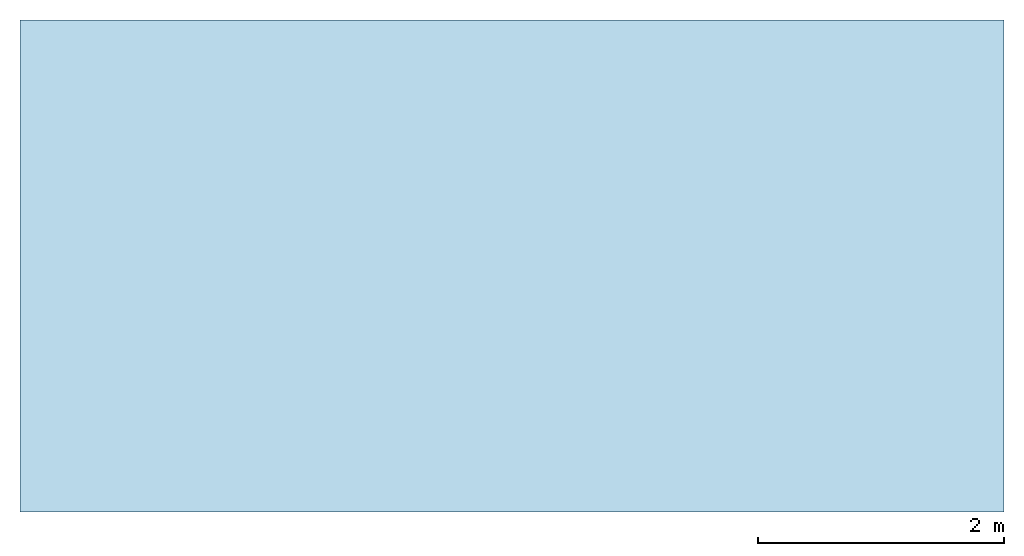
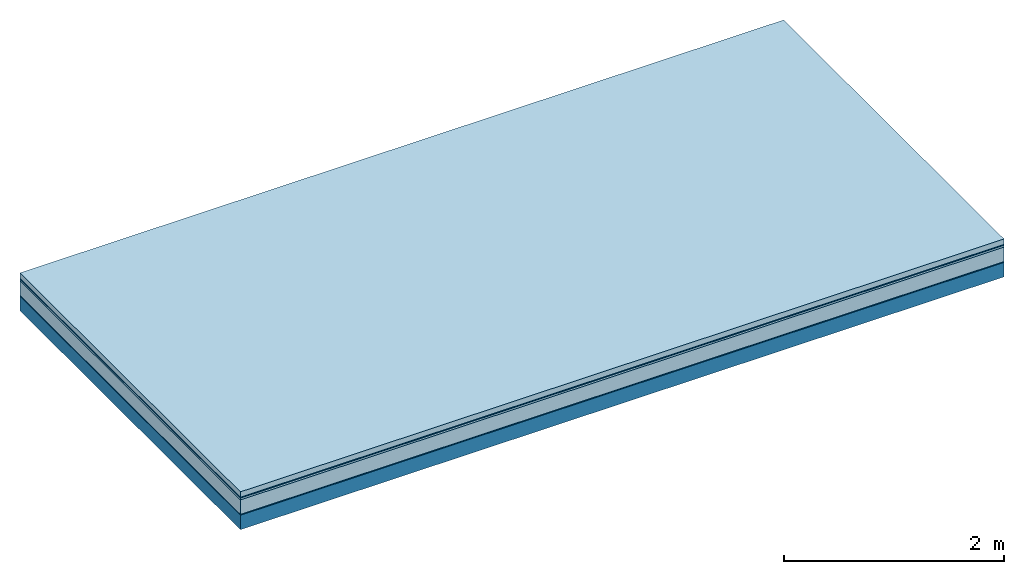
# One storey: 5 plates, 1 member, 1 element without a shape of its own.
"""IFC4 building model written with IfcOpenShell, lengths in metres."""

from ifc_helpers import new_model, si_unit, derived_unit, direction, frame, frame_2d, origin, origin_with_axes, place, context, project, spatial, rectangle, extrude, material, layer, layer_set, type_object, element, aggregate, save


model = new_model("IFC4")

# Units and contexts
plan_context = context("Plan", 3, precision=1e-05, world=origin(), true_north=direction((0.0, 1.0)))
model_context = context("Model", 3, precision=1e-05, world=origin(), true_north=direction((0.0, 1.0)))
ifc_project = project(units=[si_unit("LENGTHUNIT", "METRE"), derived_unit("SOUNDPRESSUREUNIT", [(si_unit("PRESSUREUNIT", "PASCAL", prefix="MICRO"), 0)]), si_unit("ENERGYUNIT", "JOULE", prefix="MEGA"), si_unit("MASSUNIT", "GRAM", prefix="KILO"), derived_unit("THERMALTRANSMITTANCEUNIT", [(si_unit("POWERUNIT", "WATT"), 1), (si_unit("AREAUNIT", "SQUARE_METRE"), -1), (si_unit("THERMODYNAMICTEMPERATUREUNIT", "KELVIN"), -1)]), derived_unit("AREADENSITYUNIT", [(si_unit("MASSUNIT", "GRAM", prefix="KILO"), 1), (si_unit("AREAUNIT", "SQUARE_METRE"), -1)]), derived_unit("USERDEFINED", [(si_unit("ENERGYUNIT", "JOULE", prefix="MEGA"), 1), (si_unit("AREAUNIT", "SQUARE_METRE"), -1)])], contexts=[plan_context, model_context])

# Site, building, storey
site = spatial("IfcSite", under=ifc_project)
building_placement = place(None, origin())
building = spatial("IfcBuilding", under=site, at=building_placement)
storey_placement = place(building_placement, origin())
storey = spatial("IfcBuildingStorey", under=building, at=storey_placement)

# Slab, member, plates
ifc_material_1 = material(Name="clay", Category="02.004")
ifc_layer_1 = layer(ifc_material_1, 0.06, Name="Use and protection layer 2")
ifc_material_2 = material(Name="Protective layer", Category="09.007")
ifc_layer_2 = layer(ifc_material_2, 0.01, Name="Use and protection layer 1")
ifc_material_3 = material(Name="Bituminous", Category="09.003")
ifc_layer_3 = layer(ifc_material_3, 0.02, Name="Seal")
ifc_material_4 = material(Name="Mineral wool", Category="10.008")
ifc_layer_4 = layer(ifc_material_4, 0.16, Name="Exterior insulation layer 1")
ifc_material_5 = material(Name="Vapor-permeable barrier", Category="09.006")
ifc_layer_5 = layer(ifc_material_5, 0.01, Name="layer / temporary roof")
ifc_material_6 = material(Name="no composite action")
ifc_layer_6 = layer(ifc_material_6, 0.0, Name="Bond")
ifc_layer_7 = layer(None, 0.16, Name="Support")
ifc_layer_set = layer_set([ifc_layer_1, ifc_layer_2, ifc_layer_3, ifc_layer_4, ifc_layer_5, ifc_layer_6, ifc_layer_7])
slab_type = type_object("IfcSlabType", Name="F0054", PredefinedType="NOTDEFINED", material=ifc_layer_set)
slab_placement = place(None, frame((0.0, 0.0, 0.0), z_axis=(0.0, 0.0, -1.0), x_axis=(1.0, 0.0, 0.0)))
slab = element("IfcSlab", 1, at=slab_placement, inside=storey, type_object=slab_type, material=ifc_layer_set, Name="Slab #1")
ifc_material_7 = material(Name="Solid timber panel")
member_placement = place(slab_placement, origin())
member = element("IfcMember", 2, at=member_placement, material=ifc_material_7, Name="Support", context=plan_context, shape_type="SweptSolid", body=[
    extrude(rectangle(XDim=1.0, YDim=0.16, at=frame_2d((0.5, 0.08), x_axis=(1.0, 0.0))), frame((0.0, 4.0, 0.26), z_axis=(0.0, -1.0, 0.0), x_axis=(1.0, 0.0, 0.0)), (0.0, 0.0, 1.0), 4.0),
    extrude(rectangle(XDim=1.0, YDim=0.16, at=frame_2d((0.5, 0.08), x_axis=(1.0, 0.0))), frame((1.0, 4.0, 0.26), z_axis=(0.0, -1.0, 0.0), x_axis=(1.0, 0.0, 0.0)), (0.0, 0.0, 1.0), 4.0),
    extrude(rectangle(XDim=1.0, YDim=0.16, at=frame_2d((0.5, 0.08), x_axis=(1.0, 0.0))), frame((2.0, 4.0, 0.26), z_axis=(0.0, -1.0, 0.0), x_axis=(1.0, 0.0, 0.0)), (0.0, 0.0, 1.0), 4.0),
    extrude(rectangle(XDim=1.0, YDim=0.16, at=frame_2d((0.5, 0.08), x_axis=(1.0, 0.0))), frame((3.0, 4.0, 0.26), z_axis=(0.0, -1.0, 0.0), x_axis=(1.0, 0.0, 0.0)), (0.0, 0.0, 1.0), 4.0),
    extrude(rectangle(XDim=1.0, YDim=0.16, at=frame_2d((0.5, 0.08), x_axis=(1.0, 0.0))), frame((4.0, 4.0, 0.26), z_axis=(0.0, -1.0, 0.0), x_axis=(1.0, 0.0, 0.0)), (0.0, 0.0, 1.0), 4.0),
    extrude(rectangle(XDim=1.0, YDim=0.16, at=frame_2d((0.5, 0.08), x_axis=(1.0, 0.0))), frame((5.0, 4.0, 0.26), z_axis=(0.0, -1.0, 0.0), x_axis=(1.0, 0.0, 0.0)), (0.0, 0.0, 1.0), 4.0),
    extrude(rectangle(XDim=1.0, YDim=0.16, at=frame_2d((0.5, 0.08), x_axis=(1.0, 0.0))), frame((6.0, 4.0, 0.26), z_axis=(0.0, -1.0, 0.0), x_axis=(1.0, 0.0, 0.0)), (0.0, 0.0, 1.0), 4.0),
    extrude(rectangle(XDim=1.0, YDim=0.16, at=frame_2d((0.5, 0.08), x_axis=(1.0, 0.0))), frame((7.0, 4.0, 0.26), z_axis=(0.0, -1.0, 0.0), x_axis=(1.0, 0.0, 0.0)), (0.0, 0.0, 1.0), 4.0),
])
plate_1_placement = place(slab_placement, origin())
plate_1 = element("IfcPlate", 3, at=plate_1_placement, material=ifc_material_1, Name="Use and protection layer 2", context=plan_context, shape_type="SweptSolid", body=[
    extrude(rectangle(XDim=8.0, YDim=4.0, at=frame_2d((4.0, 2.0), x_axis=(1.0, 0.0))), origin_with_axes(), (0.0, 0.0, 1.0), 0.06),
])
plate_2_placement = place(slab_placement, origin())
plate_2 = element("IfcPlate", 4, at=plate_2_placement, material=ifc_material_2, Name="Use and protection layer 1", context=plan_context, shape_type="SweptSolid", body=[
    extrude(rectangle(XDim=8.0, YDim=4.0, at=frame_2d((4.0, 2.0), x_axis=(1.0, 0.0))), frame((0.0, 0.0, 0.06), z_axis=(0.0, 0.0, 1.0), x_axis=(1.0, 0.0, 0.0)), (0.0, 0.0, 1.0), 0.01),
])
plate_3_placement = place(slab_placement, origin())
plate_3 = element("IfcPlate", 5, at=plate_3_placement, material=ifc_material_3, Name="Seal", context=plan_context, shape_type="SweptSolid", body=[
    extrude(rectangle(XDim=8.0, YDim=4.0, at=frame_2d((4.0, 2.0), x_axis=(1.0, 0.0))), frame((0.0, 0.0, 0.07), z_axis=(0.0, 0.0, 1.0), x_axis=(1.0, 0.0, 0.0)), (0.0, 0.0, 1.0), 0.02),
])
plate_4_placement = place(slab_placement, origin())
plate_4 = element("IfcPlate", 6, at=plate_4_placement, material=ifc_material_4, Name="Exterior insulation layer 1", context=plan_context, shape_type="SweptSolid", body=[
    extrude(rectangle(XDim=8.0, YDim=4.0, at=frame_2d((4.0, 2.0), x_axis=(1.0, 0.0))), frame((0.0, 0.0, 0.09), z_axis=(0.0, 0.0, 1.0), x_axis=(1.0, 0.0, 0.0)), (0.0, 0.0, 1.0), 0.16),
])
plate_5_placement = place(slab_placement, origin())
plate_5 = element("IfcPlate", 7, at=plate_5_placement, material=ifc_material_5, Name="layer / temporary roof", context=plan_context, shape_type="SweptSolid", body=[
    extrude(rectangle(XDim=8.0, YDim=4.0, at=frame_2d((4.0, 2.0), x_axis=(1.0, 0.0))), frame((0.0, 0.0, 0.25), z_axis=(0.0, 0.0, 1.0), x_axis=(1.0, 0.0, 0.0)), (0.0, 0.0, 1.0), 0.01),
])
aggregate(slab, [plate_1, plate_2, plate_3, plate_4, plate_5, member])

save(model, "model.ifc")
